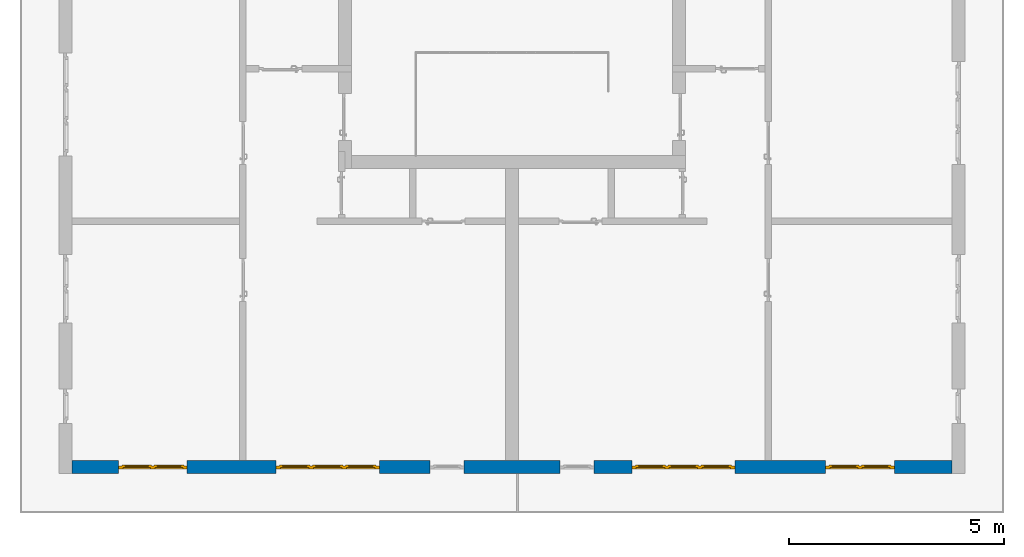
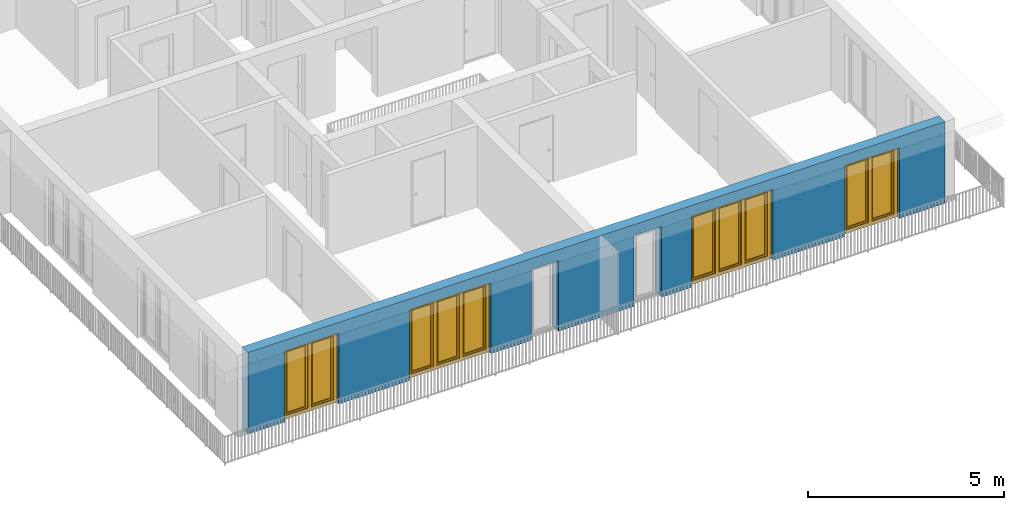
# One storey, part 9 of 54: 4 windows, 1 wall, 6 openings.
"""IFC4 building model written with IfcOpenShell, lengths in metres."""

from ifc_helpers import new_model, entity, si_unit, converted_unit, derived_unit, direction, frame, origin_with_axes, place, context, subcontext, project, spatial, polygons, source, transform, mapped, material, type_object, element, fill, save


model = new_model("IFC4")

# Units and contexts
model_context = context("Model", 3, precision=1e-05, world=origin_with_axes(), true_north=direction((0.0, 1.0)))
body_context = subcontext(model_context, "Body", "Model", "MODEL_VIEW")
ifc_project = project(units=[si_unit("LENGTHUNIT", "METRE"), si_unit("AREAUNIT", "SQUARE_METRE"), si_unit("VOLUMEUNIT", "CUBIC_METRE"), converted_unit("PLANEANGLEUNIT", "DEGREE", entity("IfcPlaneAngleMeasure", 0.0174532925199), si_unit("PLANEANGLEUNIT", "RADIAN"), dimensions=[0, 0, 0, 0, 0, 0, 0]), converted_unit("TIMEUNIT", "Year", entity("IfcTimeMeasure", 31556926.0), si_unit("TIMEUNIT", "SECOND"), dimensions=[0, 0, 1, 0, 0, 0, 0]), si_unit("MASSUNIT", "GRAM", prefix="KILO"), si_unit("THERMODYNAMICTEMPERATUREUNIT", "DEGREE_CELSIUS"), si_unit("LUMINOUSINTENSITYUNIT", "LUMEN"), si_unit("ENERGYUNIT", "JOULE", prefix="MEGA"), derived_unit("THERMALCONDUCTANCEUNIT", [(si_unit("POWERUNIT", "WATT"), 1), (si_unit("LENGTHUNIT", "METRE"), -1), (si_unit("THERMODYNAMICTEMPERATUREUNIT", "KELVIN"), -1)]), derived_unit("SPECIFICHEATCAPACITYUNIT", [(si_unit("ENERGYUNIT", "JOULE"), 1), (si_unit("MASSUNIT", "GRAM", prefix="KILO"), -1), (si_unit("THERMODYNAMICTEMPERATUREUNIT", "KELVIN"), -1)]), derived_unit("MASSDENSITYUNIT", [(si_unit("MASSUNIT", "GRAM", prefix="KILO"), 1), (si_unit("VOLUMEUNIT", "CUBIC_METRE"), -1)])], contexts=[model_context])

# Site, building, storey
site_placement = place(None, origin_with_axes())
site = spatial("IfcSite", under=ifc_project, at=site_placement, CompositionType="ELEMENT")
building_placement = place(site_placement, origin_with_axes())
building = spatial("IfcBuilding", under=site, at=building_placement, CompositionType="ELEMENT")
storey_placement = place(building_placement, frame((0.0, 0.0, 9.18), z_axis=(0.0, 0.0, 1.0), x_axis=(1.0, 0.0, 0.0)))
storey = spatial("IfcBuildingStorey", under=building, at=storey_placement, Name="3. Geschoss", CompositionType="ELEMENT", Elevation=9.18)

# Wall, openings, windows
ifc_material = material()
wall_type = type_object("IfcWallType", Name="300", PredefinedType="NOTDEFINED")
wall_placement = place(storey_placement, frame((9.3378006196, -9.92881223104, 0.0), z_axis=(0.0, 0.0, 1.0), x_axis=(-1.0, 0.0, 0.0)))
wall = element("IfcWall", 1, at=wall_placement, inside=storey, type_object=wall_type, material=ifc_material, Name="Wand-001", PredefinedType="NOTDEFINED", context=body_context, shape_type="Tessellation", body=[
    polygons([(12.4515538751, -0.3, 2.2), (12.4515538751, -0.3, 0.0), (13.63, -0.3, 0.0), (13.63, -0.3, 2.2), (16.03, -0.3, 2.2), (16.03, -0.3, 0.0), (18.0998837323, -0.3, 0.0), (18.0998837323, -0.3, 2.2), (19.6998837323, -0.3, 2.2), (19.6998837323, -0.3, 0.0), (20.78, -0.3, 0.0), (20.78, -0.3, 2.54), (0.3, -0.3, 2.54), (0.3, -0.3, 0.0), (1.6378225413, -0.3, 0.0), (1.6378225413, -0.3, 2.2), (3.2378225413, -0.3, 2.2), (3.2378225413, -0.3, 0.0), (5.35, -0.3, 0.0), (5.35, -0.3, 2.2), (7.75, -0.3, 2.2), (7.75, -0.3, 0.0), (8.62617854928, -0.3, 0.0), (8.62617854928, -0.3, 2.2), (9.42617854928, -0.3, 2.2), (9.42617854928, -0.3, 0.0), (11.6515538751, -0.3, 0.0), (11.6515538751, -0.3, 2.2), (12.4515538751, -0.1, 0.0), (12.4515538751, 0.0, 2.2), (12.4515538751, 0.0, 0.0), (13.63, 0.0, 0.0), (13.63, 0.0, 2.2), (16.03, 0.0, 2.2), (16.03, 0.0, 0.0), (18.0998837323, 0.0, 0.0), (18.0998837323, 0.0, 2.2), (19.6998837323, 0.0, 2.2), (19.6998837323, 0.0, 0.0), (20.78, 0.0, 0.0), (20.78, 0.0, 2.54), (0.3, 0.0, 2.54), (0.3, 0.0, 0.0), (1.6378225413, 0.0, 0.0), (1.6378225413, 0.0, 2.2), (3.2378225413, 0.0, 2.2), (3.2378225413, 0.0, 0.0), (5.35, 0.0, 0.0), (5.35, 0.0, 2.2), (7.75, 0.0, 2.2), (7.75, 0.0, 0.0), (8.62617854928, 0.0, 0.0), (8.62617854928, 0.0, 2.2), (9.42617854928, 0.0, 2.2), (9.42617854928, 0.0, 0.0), (11.6515538751, -0.1, 0.0), (11.6515538751, 0.0, 0.0), (11.6515538751, 0.0, 2.2)], [[[1, 2, 3, 4, 5, 6, 7, 8, 9, 10, 11, 12, 13, 14, 15, 16, 17, 18, 19, 20, 21, 22, 23, 24, 25, 26, 27, 28]], [[29, 2, 1, 30, 31]], [[2, 29, 31, 32, 3]], [[32, 33, 4, 3]], [[33, 34, 5, 4]], [[34, 35, 6, 5]], [[36, 7, 6, 35]], [[36, 37, 8, 7]], [[37, 38, 9, 8]], [[38, 39, 10, 9]], [[40, 11, 10, 39]], [[40, 41, 12, 11]], [[41, 42, 13, 12]], [[14, 13, 42, 43]], [[15, 14, 43, 44]], [[16, 15, 44, 45]], [[17, 16, 45, 46]], [[18, 17, 46, 47]], [[19, 18, 47, 48]], [[20, 19, 48, 49]], [[21, 20, 49, 50]], [[22, 21, 50, 51]], [[51, 52, 23, 22]], [[52, 53, 24, 23]], [[53, 54, 25, 24]], [[54, 55, 26, 25]], [[56, 27, 26, 55, 57]], [[28, 27, 56, 57, 58]], [[1, 28, 58, 30]], [[32, 31, 30, 58, 57, 55, 54, 53, 52, 51, 50, 49, 48, 47, 46, 45, 44, 43, 42, 41, 40, 39, 38, 37, 36, 35, 34, 33]]], closed=True),
])
opening_1_placement = place(wall_placement, frame((18.8998837323, 0.0, 0.0), z_axis=(0.0, 0.0, 1.0), x_axis=(1.0, 0.0, 0.0)))
opening_1 = element("IfcOpeningElement", 2, at=opening_1_placement, cuts=wall, Name="Fenster-001", context=body_context, identifier="Reference", shape_type="Tessellation", body=[
    polygons([(-0.8, -0.1, 0.0), (-0.8, -0.1, 2.2), (-0.8, 0.001, 2.2), (-0.8, 0.001, 0.0), (-0.8, -0.301, 0.0), (-0.8, -0.301, 2.2), (0.8, -0.1, 2.2), (0.8, 0.001, 2.2), (0.8, -0.301, 2.2), (0.8, 0.001, 0.0), (0.8, -0.1, 0.0), (0.8, -0.301, 0.0)], [[[1, 2, 3, 4]], [[2, 1, 5, 6]], [[7, 8, 3, 2, 6, 9]], [[8, 10, 4, 3]], [[1, 4, 10, 11, 12, 5]], [[6, 5, 12, 9]], [[7, 11, 10, 8]], [[11, 7, 9, 12]]], closed=True),
])
opening_2_placement = place(wall_placement, frame((2.4378225413, 0.0, 0.0), z_axis=(0.0, 0.0, 1.0), x_axis=(1.0, 0.0, 0.0)))
opening_2 = element("IfcOpeningElement", 3, at=opening_2_placement, cuts=wall, Name="Fenster-002", context=body_context, identifier="Reference", shape_type="Tessellation", body=[
    polygons([(-0.8, -0.1, 0.0), (-0.8, -0.1, 2.2), (-0.8, 0.000999999999999, 2.2), (-0.8, 0.000999999999999, 0.0), (-0.8, -0.301, 0.0), (-0.8, -0.301, 2.2), (0.8, -0.1, 2.2), (0.8, 0.000999999999999, 2.2), (0.8, -0.301, 2.2), (0.8, 0.000999999999999, 0.0), (0.8, -0.1, 0.0), (0.8, -0.301, 0.0)], [[[1, 2, 3, 4]], [[2, 1, 5, 6]], [[7, 8, 3, 2, 6, 9]], [[8, 10, 4, 3]], [[1, 4, 10, 11, 12, 5]], [[6, 5, 12, 9]], [[7, 11, 10, 8]], [[11, 7, 9, 12]]], closed=True),
])
opening_3_placement = place(wall_placement, frame((14.83, 0.0, 0.0), z_axis=(0.0, 0.0, 1.0), x_axis=(1.0, 0.0, 0.0)))
opening_3 = element("IfcOpeningElement", 4, at=opening_3_placement, cuts=wall, Name="Fenster-002", context=body_context, identifier="Reference", shape_type="Tessellation", body=[
    polygons([(-1.2, -0.1, 0.0), (-1.2, -0.1, 2.2), (-1.2, 0.001, 2.2), (-1.2, 0.001, 0.0), (-1.2, -0.301, 0.0), (-1.2, -0.301, 2.2), (1.2, -0.1, 2.2), (1.2, 0.001, 2.2), (1.2, -0.301, 2.2), (1.2, 0.001, 0.0), (1.2, -0.1, 0.0), (1.2, -0.301, 0.0)], [[[1, 2, 3, 4]], [[2, 1, 5, 6]], [[7, 8, 3, 2, 6, 9]], [[8, 10, 4, 3]], [[1, 4, 10, 11, 12, 5]], [[6, 5, 12, 9]], [[7, 11, 10, 8]], [[11, 7, 9, 12]]], closed=True),
])
opening_4_placement = place(wall_placement, frame((6.55, 0.0, 0.0), z_axis=(0.0, 0.0, 1.0), x_axis=(1.0, 0.0, 0.0)))
opening_4 = element("IfcOpeningElement", 5, at=opening_4_placement, cuts=wall, Name="Fenster-003", context=body_context, identifier="Reference", shape_type="Tessellation", body=[
    polygons([(-1.2, -0.1, 0.0), (-1.2, -0.1, 2.2), (-1.2, 0.000999999999999, 2.2), (-1.2, 0.000999999999999, 0.0), (-1.2, -0.301, 0.0), (-1.2, -0.301, 2.2), (1.2, -0.1, 2.2), (1.2, 0.001, 2.2), (1.2, -0.301, 2.2), (1.2, 0.001, 0.0), (1.2, -0.1, 0.0), (1.2, -0.301, 0.0)], [[[1, 2, 3, 4]], [[2, 1, 5, 6]], [[7, 8, 3, 2, 6, 9]], [[8, 10, 4, 3]], [[1, 4, 10, 11, 12, 5]], [[6, 5, 12, 9]], [[7, 11, 10, 8]], [[11, 7, 9, 12]]], closed=True),
])
opening_5_placement = place(wall_placement, frame((9.02617854928, 0.0, 0.0), z_axis=(0.0, 0.0, 1.0), x_axis=(1.0, 0.0, 0.0)))
element("IfcOpeningElement", 6, at=opening_5_placement, cuts=wall, Name="Fenster-003", context=body_context, identifier="Reference", shape_type="Tessellation", body=[
    polygons([(-0.4, -0.1, 0.0), (-0.4, -0.1, 2.2), (-0.4, 0.001, 2.2), (-0.4, 0.001, 0.0), (-0.4, -0.301, 0.0), (-0.4, -0.301, 2.2), (0.4, -0.1, 2.2), (0.4, 0.001, 2.2), (0.4, -0.301, 2.2), (0.4, 0.001, 0.0), (0.4, -0.1, 0.0), (0.4, -0.301, 0.0)], [[[1, 2, 3, 4]], [[2, 1, 5, 6]], [[7, 8, 3, 2, 6, 9]], [[8, 10, 4, 3]], [[1, 4, 10, 11, 12, 5]], [[6, 5, 12, 9]], [[7, 11, 10, 8]], [[11, 7, 9, 12]]], closed=True),
])
opening_6_placement = place(wall_placement, frame((12.0515538751, 0.0, 0.0), z_axis=(0.0, 0.0, 1.0), x_axis=(1.0, 0.0, 0.0)))
element("IfcOpeningElement", 7, at=opening_6_placement, cuts=wall, Name="Fenster-003", context=body_context, identifier="Reference", shape_type="Tessellation", body=[
    polygons([(-0.4, -0.1, 0.0), (-0.4, -0.1, 2.2), (-0.4, 0.001, 2.2), (-0.4, 0.001, 0.0), (-0.4, -0.301, 0.0), (-0.4, -0.301, 2.2), (0.4, -0.1, 2.2), (0.4, 0.001, 2.2), (0.4, -0.301, 2.2), (0.4, 0.001, 0.0), (0.4, -0.1, 0.0), (0.4, -0.301, 0.0)], [[[1, 2, 3, 4]], [[2, 1, 5, 6]], [[7, 8, 3, 2, 6, 9]], [[8, 10, 4, 3]], [[1, 4, 10, 11, 12, 5]], [[6, 5, 12, 9]], [[7, 11, 10, 8]], [[11, 7, 9, 12]]], closed=True),
])
window_type_1 = type_object("IfcWindowType", Name="2-1+1 26", PartitioningType="DOUBLE_PANEL_VERTICAL", PredefinedType="WINDOW")
shared_shape_1 = source(origin_with_axes(), body_context, "Body", "Tessellation", [
    polygons([(-0.8, -0.07, 0.0), (-0.8, 0.0, 0.0), (-0.7, 0.0, 0.1), (-0.7, -0.07, 0.1), (-0.8, -0.07, 2.2), (-0.8, 0.0, 2.2), (-0.7, 0.0, 2.1), (-0.7, -0.07, 2.1)], [[[1, 2, 3, 4]], [[5, 6, 2, 1]], [[2, 6, 7, 3]], [[4, 3, 7, 8]], [[1, 4, 8, 5]], [[8, 7, 6, 5]]], closed=True),
    polygons([(0.8, -0.07, 0.0), (0.8, 0.0, 0.0), (0.8, 0.0, 2.2), (0.8, -0.07, 2.2), (0.7, -0.07, 0.1), (0.7, 0.0, 0.1), (0.7, 0.0, 2.1), (0.7, -0.07, 2.1)], [[[1, 2, 3, 4]], [[5, 6, 2, 1]], [[2, 6, 7, 3]], [[4, 3, 7, 8]], [[1, 4, 8, 5]], [[8, 7, 6, 5]]], closed=True),
    polygons([(-0.8, -0.07, 0.0), (-0.8, 0.0, 0.0), (0.8, 0.0, 0.0), (0.8, -0.07, 0.0), (-0.7, -0.07, 0.1), (-0.7, 0.0, 0.1), (-0.05, 0.0, 0.1), (0.05, 0.0, 0.1), (0.7, 0.0, 0.1), (0.7, -0.07, 0.1), (0.05, -0.07, 0.1), (-0.05, -0.07, 0.1)], [[[1, 2, 3, 4]], [[5, 6, 2, 1]], [[2, 6, 7, 8, 9, 3]], [[4, 3, 9, 10]], [[1, 4, 10, 11, 12, 5]], [[12, 7, 6, 5]], [[11, 8, 7, 12]], [[10, 9, 8, 11]]], closed=True),
    polygons([(-0.8, -0.07, 2.2), (-0.8, 0.0, 2.2), (-0.7, 0.0, 2.1), (-0.7, -0.07, 2.1), (0.8, -0.07, 2.2), (0.8, 0.0, 2.2), (0.7, 0.0, 2.1), (0.05, 0.0, 2.1), (-0.05, 0.0, 2.1), (-0.05, -0.07, 2.1), (0.05, -0.07, 2.1), (0.7, -0.07, 2.1)], [[[1, 2, 3, 4]], [[5, 6, 2, 1]], [[2, 6, 7, 8, 9, 3]], [[4, 3, 9, 10]], [[1, 4, 10, 11, 12, 5]], [[12, 7, 6, 5]], [[11, 8, 7, 12]], [[10, 9, 8, 11]]], closed=True),
    polygons([(-0.05, -0.07, 0.1), (-0.05, 0.0, 0.1), (0.05, 0.0, 0.1), (0.05, -0.07, 0.1), (-0.05, -0.07, 2.1), (-0.05, 0.0, 2.1), (0.05, 0.0, 2.1), (0.05, -0.07, 2.1)], [[[1, 2, 3, 4]], [[5, 6, 2, 1]], [[2, 6, 7, 3]], [[4, 3, 7, 8]], [[1, 4, 8, 5]], [[8, 7, 6, 5]]], closed=True),
    polygons([(-0.72, 0.0, 0.08), (-0.72, 0.03, 0.08), (-0.65, 0.03, 0.15), (-0.65, 0.0, 0.15), (-0.72, 0.0, 2.12), (-0.72, 0.03, 2.12), (-0.65, 0.03, 2.05), (-0.65, 0.0, 2.05)], [[[1, 2, 3, 4]], [[5, 6, 2, 1]], [[2, 6, 7, 3]], [[4, 3, 7, 8]], [[1, 4, 8, 5]], [[8, 7, 6, 5]]], closed=True),
    polygons([(-0.03, 0.0, 0.08), (-0.1, 0.0, 0.15), (-0.1, 0.03, 0.15), (-0.03, 0.03, 0.08), (-0.03, 0.0, 2.12), (-0.1, 0.0, 2.05), (-0.1, 0.03, 2.05), (-0.03, 0.03, 2.12)], [[[1, 2, 3, 4]], [[1, 5, 6, 2]], [[2, 6, 7, 3]], [[4, 3, 7, 8]], [[5, 1, 4, 8]], [[6, 5, 8, 7]]], closed=True),
    polygons([(-0.72, 0.0, 0.08), (-0.72, 0.03, 0.08), (-0.03, 0.03, 0.08), (-0.03, 0.0, 0.08), (-0.65, 0.0, 0.15), (-0.65, 0.03, 0.15), (-0.1, 0.03, 0.15), (-0.1, 0.0, 0.15)], [[[1, 2, 3, 4]], [[5, 6, 2, 1]], [[2, 6, 7, 3]], [[4, 3, 7, 8]], [[1, 4, 8, 5]], [[8, 7, 6, 5]]], closed=True),
    polygons([(-0.72, 0.0, 2.12), (-0.03, 0.0, 2.12), (-0.03, 0.03, 2.12), (-0.72, 0.03, 2.12), (-0.65, 0.0, 2.05), (-0.1, 0.0, 2.05), (-0.1, 0.03, 2.05), (-0.65, 0.03, 2.05)], [[[1, 2, 3, 4]], [[1, 5, 6, 2]], [[2, 6, 7, 3]], [[4, 3, 7, 8]], [[5, 1, 4, 8]], [[6, 5, 8, 7]]], closed=True),
    polygons([(-0.7, -0.03, 0.1), (-0.7, 0.0, 0.1), (-0.65, 0.0, 0.15), (-0.65, -0.03, 0.15), (-0.7, -0.03, 2.1), (-0.7, 0.0, 2.1), (-0.65, 0.0, 2.05), (-0.65, -0.03, 2.05)], [[[1, 2, 3, 4]], [[5, 6, 2, 1]], [[2, 6, 7, 3]], [[4, 3, 7, 8]], [[1, 4, 8, 5]], [[8, 7, 6, 5]]], closed=True),
    polygons([(-0.05, -0.03, 0.1), (-0.1, -0.03, 0.15), (-0.1, 0.0, 0.15), (-0.05, 0.0, 0.1), (-0.05, -0.03, 2.1), (-0.1, -0.03, 2.05), (-0.1, 0.0, 2.05), (-0.05, 0.0, 2.1)], [[[1, 2, 3, 4]], [[1, 5, 6, 2]], [[2, 6, 7, 3]], [[4, 3, 7, 8]], [[5, 1, 4, 8]], [[6, 5, 8, 7]]], closed=True),
    polygons([(-0.7, -0.03, 0.1), (-0.7, 0.0, 0.1), (-0.05, 0.0, 0.1), (-0.05, -0.03, 0.1), (-0.65, -0.03, 0.15), (-0.65, 0.0, 0.15), (-0.1, 0.0, 0.15), (-0.1, -0.03, 0.15)], [[[1, 2, 3, 4]], [[5, 6, 2, 1]], [[2, 6, 7, 3]], [[4, 3, 7, 8]], [[1, 4, 8, 5]], [[8, 7, 6, 5]]], closed=True),
    polygons([(-0.7, -0.03, 2.1), (-0.05, -0.03, 2.1), (-0.05, 0.0, 2.1), (-0.7, 0.0, 2.1), (-0.65, -0.03, 2.05), (-0.1, -0.03, 2.05), (-0.1, 0.0, 2.05), (-0.65, 0.0, 2.05)], [[[1, 2, 3, 4]], [[1, 5, 6, 2]], [[2, 6, 7, 3]], [[4, 3, 7, 8]], [[5, 1, 4, 8]], [[6, 5, 8, 7]]], closed=True),
    polygons([(-0.65, -0.005, 0.15), (-0.65, 0.005, 0.15), (-0.1, 0.005, 0.15), (-0.1, -0.005, 0.15), (-0.65, -0.005, 2.05), (-0.65, 0.005, 2.05), (-0.1, 0.005, 2.05), (-0.1, -0.005, 2.05)], [[[1, 2, 3, 4]], [[5, 6, 2, 1]], [[2, 6, 7, 3]], [[4, 3, 7, 8]], [[1, 4, 8, 5]], [[8, 7, 6, 5]]], closed=True),
    polygons([(0.03, 0.0, 0.08), (0.03, 0.03, 0.08), (0.1, 0.03, 0.15), (0.1, 0.0, 0.15), (0.03, 0.0, 2.12), (0.03, 0.03, 2.12), (0.1, 0.03, 2.05), (0.1, 0.0, 2.05)], [[[1, 2, 3, 4]], [[5, 6, 2, 1]], [[2, 6, 7, 3]], [[4, 3, 7, 8]], [[1, 4, 8, 5]], [[8, 7, 6, 5]]], closed=True),
    polygons([(0.72, 0.0, 0.08), (0.65, 0.0, 0.15), (0.65, 0.03, 0.15), (0.72, 0.03, 0.08), (0.72, 0.0, 2.12), (0.65, 0.0, 2.05), (0.65, 0.03, 2.05), (0.72, 0.03, 2.12)], [[[1, 2, 3, 4]], [[1, 5, 6, 2]], [[2, 6, 7, 3]], [[4, 3, 7, 8]], [[5, 1, 4, 8]], [[6, 5, 8, 7]]], closed=True),
    polygons([(0.03, 0.0, 0.08), (0.03, 0.03, 0.08), (0.72, 0.03, 0.08), (0.72, 0.0, 0.08), (0.1, 0.0, 0.15), (0.1, 0.03, 0.15), (0.65, 0.03, 0.15), (0.65, 0.0, 0.15)], [[[1, 2, 3, 4]], [[5, 6, 2, 1]], [[2, 6, 7, 3]], [[4, 3, 7, 8]], [[1, 4, 8, 5]], [[8, 7, 6, 5]]], closed=True),
    polygons([(0.03, 0.0, 2.12), (0.72, 0.0, 2.12), (0.72, 0.03, 2.12), (0.03, 0.03, 2.12), (0.1, 0.0, 2.05), (0.65, 0.0, 2.05), (0.65, 0.03, 2.05), (0.1, 0.03, 2.05)], [[[1, 2, 3, 4]], [[1, 5, 6, 2]], [[2, 6, 7, 3]], [[4, 3, 7, 8]], [[5, 1, 4, 8]], [[6, 5, 8, 7]]], closed=True),
    polygons([(0.05, -0.03, 0.1), (0.05, 0.0, 0.1), (0.1, 0.0, 0.15), (0.1, -0.03, 0.15), (0.05, -0.03, 2.1), (0.05, 0.0, 2.1), (0.1, 0.0, 2.05), (0.1, -0.03, 2.05)], [[[1, 2, 3, 4]], [[5, 6, 2, 1]], [[2, 6, 7, 3]], [[4, 3, 7, 8]], [[1, 4, 8, 5]], [[8, 7, 6, 5]]], closed=True),
    polygons([(0.7, -0.03, 0.1), (0.65, -0.03, 0.15), (0.65, 0.0, 0.15), (0.7, 0.0, 0.1), (0.7, -0.03, 2.1), (0.65, -0.03, 2.05), (0.65, 0.0, 2.05), (0.7, 0.0, 2.1)], [[[1, 2, 3, 4]], [[1, 5, 6, 2]], [[2, 6, 7, 3]], [[4, 3, 7, 8]], [[5, 1, 4, 8]], [[6, 5, 8, 7]]], closed=True),
    polygons([(0.05, -0.03, 0.1), (0.05, 0.0, 0.1), (0.7, 0.0, 0.1), (0.7, -0.03, 0.1), (0.1, -0.03, 0.15), (0.1, 0.0, 0.15), (0.65, 0.0, 0.15), (0.65, -0.03, 0.15)], [[[1, 2, 3, 4]], [[5, 6, 2, 1]], [[2, 6, 7, 3]], [[4, 3, 7, 8]], [[1, 4, 8, 5]], [[8, 7, 6, 5]]], closed=True),
    polygons([(0.05, -0.03, 2.1), (0.7, -0.03, 2.1), (0.7, 0.0, 2.1), (0.05, 0.0, 2.1), (0.1, -0.03, 2.05), (0.65, -0.03, 2.05), (0.65, 0.0, 2.05), (0.1, 0.0, 2.05)], [[[1, 2, 3, 4]], [[1, 5, 6, 2]], [[2, 6, 7, 3]], [[4, 3, 7, 8]], [[5, 1, 4, 8]], [[6, 5, 8, 7]]], closed=True),
    polygons([(0.1, -0.005, 0.15), (0.1, 0.005, 0.15), (0.65, 0.005, 0.15), (0.65, -0.005, 0.15), (0.1, -0.005, 2.05), (0.1, 0.005, 2.05), (0.65, 0.005, 2.05), (0.65, -0.005, 2.05)], [[[1, 2, 3, 4]], [[5, 6, 2, 1]], [[2, 6, 7, 3]], [[4, 3, 7, 8]], [[1, 4, 8, 5]], [[8, 7, 6, 5]]], closed=True),
])
window_1_placement = place(opening_1_placement, frame((0.8, 0.0, 0.0), z_axis=(0.0, 0.0, 1.0), x_axis=(-1.0, 0.0, 0.0)))
window_1 = element("IfcWindow", 8, at=window_1_placement, inside=storey, type_object=window_type_1, Name="Fenster-001", OverallHeight=2.2, OverallWidth=1.6, PredefinedType="WINDOW", context=body_context, shape_type="MappedRepresentation", body=[
    mapped(shared_shape_1, transform((0.8, 0.17, 0.0))),
])
fill(opening_1, window_1)
window_2_placement = place(opening_2_placement, frame((0.8, 0.0, 0.0), z_axis=(0.0, 0.0, 1.0), x_axis=(-1.0, 0.0, 0.0)))
window_2 = element("IfcWindow", 9, at=window_2_placement, inside=storey, type_object=window_type_1, Name="Fenster-002", OverallHeight=2.2, OverallWidth=1.6, PredefinedType="WINDOW", context=body_context, shape_type="MappedRepresentation", body=[
    mapped(shared_shape_1, transform((0.8, 0.17, 0.0))),
])
fill(opening_2, window_2)
window_type_2 = type_object("IfcWindowType", Name="3-1+1+1 26", PartitioningType="TRIPLE_PANEL_VERTICAL", PredefinedType="WINDOW")
shared_shape_2 = source(origin_with_axes(), body_context, "Body", "Tessellation", [
    polygons([(-1.2, -0.07, 0.0), (-1.2, 0.0, 0.0), (-1.1, 0.0, 0.1), (-1.1, -0.07, 0.1), (-1.2, -0.07, 2.2), (-1.2, 0.0, 2.2), (-1.1, 0.0, 2.1), (-1.1, -0.07, 2.1)], [[[1, 2, 3, 4]], [[5, 6, 2, 1]], [[2, 6, 7, 3]], [[4, 3, 7, 8]], [[1, 4, 8, 5]], [[8, 7, 6, 5]]], closed=True),
    polygons([(1.2, -0.07, 0.0), (1.2, 0.0, 0.0), (1.2, 0.0, 2.2), (1.2, -0.07, 2.2), (1.1, -0.07, 0.1), (1.1, 0.0, 0.1), (1.1, 0.0, 2.1), (1.1, -0.07, 2.1)], [[[1, 2, 3, 4]], [[5, 6, 2, 1]], [[2, 6, 7, 3]], [[4, 3, 7, 8]], [[1, 4, 8, 5]], [[8, 7, 6, 5]]], closed=True),
    polygons([(-1.2, -0.07, 0.0), (-1.2, 0.0, 0.0), (1.2, 0.0, 0.0), (1.2, -0.07, 0.0), (-1.1, -0.07, 0.1), (-1.1, 0.0, 0.1), (-0.433333333333, 0.0, 0.1), (-0.333333333333, 0.0, 0.1), (0.333333333333, 0.0, 0.1), (0.433333333333, 0.0, 0.1), (1.1, 0.0, 0.1), (1.1, -0.07, 0.1), (0.433333333333, -0.07, 0.1), (0.333333333333, -0.07, 0.1), (-0.333333333333, -0.07, 0.1), (-0.433333333333, -0.07, 0.1)], [[[1, 2, 3, 4]], [[5, 6, 2, 1]], [[2, 6, 7, 8, 9, 10, 11, 3]], [[4, 3, 11, 12]], [[1, 4, 12, 13, 14, 15, 16, 5]], [[16, 7, 6, 5]], [[15, 8, 7, 16]], [[14, 9, 8, 15]], [[13, 10, 9, 14]], [[12, 11, 10, 13]]], closed=True),
    polygons([(-1.2, -0.07, 2.2), (-1.2, 0.0, 2.2), (-1.1, 0.0, 2.1), (-1.1, -0.07, 2.1), (1.2, -0.07, 2.2), (1.2, 0.0, 2.2), (1.1, 0.0, 2.1), (0.433333333333, 0.0, 2.1), (0.333333333333, 0.0, 2.1), (-0.333333333333, 0.0, 2.1), (-0.433333333333, 0.0, 2.1), (-0.433333333333, -0.07, 2.1), (-0.333333333333, -0.07, 2.1), (0.333333333333, -0.07, 2.1), (0.433333333333, -0.07, 2.1), (1.1, -0.07, 2.1)], [[[1, 2, 3, 4]], [[5, 6, 2, 1]], [[2, 6, 7, 8, 9, 10, 11, 3]], [[4, 3, 11, 12]], [[1, 4, 12, 13, 14, 15, 16, 5]], [[16, 7, 6, 5]], [[15, 8, 7, 16]], [[14, 9, 8, 15]], [[13, 10, 9, 14]], [[12, 11, 10, 13]]], closed=True),
    polygons([(0.333333333333, -0.07, 0.1), (0.333333333333, 0.0, 0.1), (0.433333333333, 0.0, 0.1), (0.433333333333, -0.07, 0.1), (0.333333333333, -0.07, 2.1), (0.333333333333, 0.0, 2.1), (0.433333333333, 0.0, 2.1), (0.433333333333, -0.07, 2.1)], [[[1, 2, 3, 4]], [[5, 6, 2, 1]], [[2, 6, 7, 3]], [[4, 3, 7, 8]], [[1, 4, 8, 5]], [[8, 7, 6, 5]]], closed=True),
    polygons([(-0.433333333333, -0.07, 0.1), (-0.433333333333, 0.0, 0.1), (-0.333333333333, 0.0, 0.1), (-0.333333333333, -0.07, 0.1), (-0.433333333333, -0.07, 2.1), (-0.433333333333, 0.0, 2.1), (-0.333333333333, 0.0, 2.1), (-0.333333333333, -0.07, 2.1)], [[[1, 2, 3, 4]], [[5, 6, 2, 1]], [[2, 6, 7, 3]], [[4, 3, 7, 8]], [[1, 4, 8, 5]], [[8, 7, 6, 5]]], closed=True),
    polygons([(-1.12, 0.0, 0.08), (-1.12, 0.03, 0.08), (-1.05, 0.03, 0.15), (-1.05, 0.0, 0.15), (-1.12, 0.0, 2.12), (-1.12, 0.03, 2.12), (-1.05, 0.03, 2.05), (-1.05, 0.0, 2.05)], [[[1, 2, 3, 4]], [[5, 6, 2, 1]], [[2, 6, 7, 3]], [[4, 3, 7, 8]], [[1, 4, 8, 5]], [[8, 7, 6, 5]]], closed=True),
    polygons([(-0.413333333333, 0.0, 0.08), (-0.483333333333, 0.0, 0.15), (-0.483333333333, 0.03, 0.15), (-0.413333333333, 0.03, 0.08), (-0.413333333333, 0.0, 2.12), (-0.483333333333, 0.0, 2.05), (-0.483333333333, 0.03, 2.05), (-0.413333333333, 0.03, 2.12)], [[[1, 2, 3, 4]], [[1, 5, 6, 2]], [[2, 6, 7, 3]], [[4, 3, 7, 8]], [[5, 1, 4, 8]], [[6, 5, 8, 7]]], closed=True),
    polygons([(-1.12, 0.0, 0.08), (-1.12, 0.03, 0.08), (-0.413333333333, 0.03, 0.08), (-0.413333333333, 0.0, 0.08), (-1.05, 0.0, 0.15), (-1.05, 0.03, 0.15), (-0.483333333333, 0.03, 0.15), (-0.483333333333, 0.0, 0.15)], [[[1, 2, 3, 4]], [[5, 6, 2, 1]], [[2, 6, 7, 3]], [[4, 3, 7, 8]], [[1, 4, 8, 5]], [[8, 7, 6, 5]]], closed=True),
    polygons([(-1.12, 0.0, 2.12), (-0.413333333333, 0.0, 2.12), (-0.413333333333, 0.03, 2.12), (-1.12, 0.03, 2.12), (-1.05, 0.0, 2.05), (-0.483333333333, 0.0, 2.05), (-0.483333333333, 0.03, 2.05), (-1.05, 0.03, 2.05)], [[[1, 2, 3, 4]], [[1, 5, 6, 2]], [[2, 6, 7, 3]], [[4, 3, 7, 8]], [[5, 1, 4, 8]], [[6, 5, 8, 7]]], closed=True),
    polygons([(-1.1, -0.03, 0.1), (-1.1, 0.0, 0.1), (-1.05, 0.0, 0.15), (-1.05, -0.03, 0.15), (-1.1, -0.03, 2.1), (-1.1, 0.0, 2.1), (-1.05, 0.0, 2.05), (-1.05, -0.03, 2.05)], [[[1, 2, 3, 4]], [[5, 6, 2, 1]], [[2, 6, 7, 3]], [[4, 3, 7, 8]], [[1, 4, 8, 5]], [[8, 7, 6, 5]]], closed=True),
    polygons([(-0.433333333333, -0.03, 0.1), (-0.483333333333, -0.03, 0.15), (-0.483333333333, 0.0, 0.15), (-0.433333333333, 0.0, 0.1), (-0.433333333333, -0.03, 2.1), (-0.483333333333, -0.03, 2.05), (-0.483333333333, 0.0, 2.05), (-0.433333333333, 0.0, 2.1)], [[[1, 2, 3, 4]], [[1, 5, 6, 2]], [[2, 6, 7, 3]], [[4, 3, 7, 8]], [[5, 1, 4, 8]], [[6, 5, 8, 7]]], closed=True),
    polygons([(-1.1, -0.03, 0.1), (-1.1, 0.0, 0.1), (-0.433333333333, 0.0, 0.1), (-0.433333333333, -0.03, 0.1), (-1.05, -0.03, 0.15), (-1.05, 0.0, 0.15), (-0.483333333333, 0.0, 0.15), (-0.483333333333, -0.03, 0.15)], [[[1, 2, 3, 4]], [[5, 6, 2, 1]], [[2, 6, 7, 3]], [[4, 3, 7, 8]], [[1, 4, 8, 5]], [[8, 7, 6, 5]]], closed=True),
    polygons([(-1.1, -0.03, 2.1), (-0.433333333333, -0.03, 2.1), (-0.433333333333, 0.0, 2.1), (-1.1, 0.0, 2.1), (-1.05, -0.03, 2.05), (-0.483333333333, -0.03, 2.05), (-0.483333333333, 0.0, 2.05), (-1.05, 0.0, 2.05)], [[[1, 2, 3, 4]], [[1, 5, 6, 2]], [[2, 6, 7, 3]], [[4, 3, 7, 8]], [[5, 1, 4, 8]], [[6, 5, 8, 7]]], closed=True),
    polygons([(-1.05, -0.005, 0.15), (-1.05, 0.005, 0.15), (-0.483333333333, 0.005, 0.15), (-0.483333333333, -0.005, 0.15), (-1.05, -0.005, 2.05), (-1.05, 0.005, 2.05), (-0.483333333333, 0.005, 2.05), (-0.483333333333, -0.005, 2.05)], [[[1, 2, 3, 4]], [[5, 6, 2, 1]], [[2, 6, 7, 3]], [[4, 3, 7, 8]], [[1, 4, 8, 5]], [[8, 7, 6, 5]]], closed=True),
    polygons([(-0.353333333333, 0.0, 0.08), (-0.353333333333, 0.03, 0.08), (-0.283333333333, 0.03, 0.15), (-0.283333333333, 0.0, 0.15), (-0.353333333333, 0.0, 2.12), (-0.353333333333, 0.03, 2.12), (-0.283333333333, 0.03, 2.05), (-0.283333333333, 0.0, 2.05)], [[[1, 2, 3, 4]], [[5, 6, 2, 1]], [[2, 6, 7, 3]], [[4, 3, 7, 8]], [[1, 4, 8, 5]], [[8, 7, 6, 5]]], closed=True),
    polygons([(0.353333333333, 0.0, 0.08), (0.283333333333, 0.0, 0.15), (0.283333333333, 0.03, 0.15), (0.353333333333, 0.03, 0.08), (0.353333333333, 0.0, 2.12), (0.283333333333, 0.0, 2.05), (0.283333333333, 0.03, 2.05), (0.353333333333, 0.03, 2.12)], [[[1, 2, 3, 4]], [[1, 5, 6, 2]], [[2, 6, 7, 3]], [[4, 3, 7, 8]], [[5, 1, 4, 8]], [[6, 5, 8, 7]]], closed=True),
    polygons([(-0.353333333333, 0.0, 0.08), (-0.353333333333, 0.03, 0.08), (0.353333333333, 0.03, 0.08), (0.353333333333, 0.0, 0.08), (-0.283333333333, 0.0, 0.15), (-0.283333333333, 0.03, 0.15), (0.283333333333, 0.03, 0.15), (0.283333333333, 0.0, 0.15)], [[[1, 2, 3, 4]], [[5, 6, 2, 1]], [[2, 6, 7, 3]], [[4, 3, 7, 8]], [[1, 4, 8, 5]], [[8, 7, 6, 5]]], closed=True),
    polygons([(-0.353333333333, 0.0, 2.12), (0.353333333333, 0.0, 2.12), (0.353333333333, 0.03, 2.12), (-0.353333333333, 0.03, 2.12), (-0.283333333333, 0.0, 2.05), (0.283333333333, 0.0, 2.05), (0.283333333333, 0.03, 2.05), (-0.283333333333, 0.03, 2.05)], [[[1, 2, 3, 4]], [[1, 5, 6, 2]], [[2, 6, 7, 3]], [[4, 3, 7, 8]], [[5, 1, 4, 8]], [[6, 5, 8, 7]]], closed=True),
    polygons([(-0.333333333333, -0.03, 0.1), (-0.333333333333, 0.0, 0.1), (-0.283333333333, 0.0, 0.15), (-0.283333333333, -0.03, 0.15), (-0.333333333333, -0.03, 2.1), (-0.333333333333, 0.0, 2.1), (-0.283333333333, 0.0, 2.05), (-0.283333333333, -0.03, 2.05)], [[[1, 2, 3, 4]], [[5, 6, 2, 1]], [[2, 6, 7, 3]], [[4, 3, 7, 8]], [[1, 4, 8, 5]], [[8, 7, 6, 5]]], closed=True),
    polygons([(0.333333333333, -0.03, 0.1), (0.283333333333, -0.03, 0.15), (0.283333333333, 0.0, 0.15), (0.333333333333, 0.0, 0.1), (0.333333333333, -0.03, 2.1), (0.283333333333, -0.03, 2.05), (0.283333333333, 0.0, 2.05), (0.333333333333, 0.0, 2.1)], [[[1, 2, 3, 4]], [[1, 5, 6, 2]], [[2, 6, 7, 3]], [[4, 3, 7, 8]], [[5, 1, 4, 8]], [[6, 5, 8, 7]]], closed=True),
    polygons([(-0.333333333333, -0.03, 0.1), (-0.333333333333, 0.0, 0.1), (0.333333333333, 0.0, 0.1), (0.333333333333, -0.03, 0.1), (-0.283333333333, -0.03, 0.15), (-0.283333333333, 0.0, 0.15), (0.283333333333, 0.0, 0.15), (0.283333333333, -0.03, 0.15)], [[[1, 2, 3, 4]], [[5, 6, 2, 1]], [[2, 6, 7, 3]], [[4, 3, 7, 8]], [[1, 4, 8, 5]], [[8, 7, 6, 5]]], closed=True),
    polygons([(-0.333333333333, -0.03, 2.1), (0.333333333333, -0.03, 2.1), (0.333333333333, 0.0, 2.1), (-0.333333333333, 0.0, 2.1), (-0.283333333333, -0.03, 2.05), (0.283333333333, -0.03, 2.05), (0.283333333333, 0.0, 2.05), (-0.283333333333, 0.0, 2.05)], [[[1, 2, 3, 4]], [[1, 5, 6, 2]], [[2, 6, 7, 3]], [[4, 3, 7, 8]], [[5, 1, 4, 8]], [[6, 5, 8, 7]]], closed=True),
    polygons([(-0.283333333333, -0.005, 0.15), (-0.283333333333, 0.005, 0.15), (0.283333333333, 0.005, 0.15), (0.283333333333, -0.005, 0.15), (-0.283333333333, -0.005, 2.05), (-0.283333333333, 0.005, 2.05), (0.283333333333, 0.005, 2.05), (0.283333333333, -0.005, 2.05)], [[[1, 2, 3, 4]], [[5, 6, 2, 1]], [[2, 6, 7, 3]], [[4, 3, 7, 8]], [[1, 4, 8, 5]], [[8, 7, 6, 5]]], closed=True),
    polygons([(0.413333333333, 0.0, 0.08), (0.413333333333, 0.03, 0.08), (0.483333333333, 0.03, 0.15), (0.483333333333, 0.0, 0.15), (0.413333333333, 0.0, 2.12), (0.413333333333, 0.03, 2.12), (0.483333333333, 0.03, 2.05), (0.483333333333, 0.0, 2.05)], [[[1, 2, 3, 4]], [[5, 6, 2, 1]], [[2, 6, 7, 3]], [[4, 3, 7, 8]], [[1, 4, 8, 5]], [[8, 7, 6, 5]]], closed=True),
    polygons([(1.12, 0.0, 0.08), (1.05, 0.0, 0.15), (1.05, 0.03, 0.15), (1.12, 0.03, 0.08), (1.12, 0.0, 2.12), (1.05, 0.0, 2.05), (1.05, 0.03, 2.05), (1.12, 0.03, 2.12)], [[[1, 2, 3, 4]], [[1, 5, 6, 2]], [[2, 6, 7, 3]], [[4, 3, 7, 8]], [[5, 1, 4, 8]], [[6, 5, 8, 7]]], closed=True),
    polygons([(0.413333333333, 0.0, 0.08), (0.413333333333, 0.03, 0.08), (1.12, 0.03, 0.08), (1.12, 0.0, 0.08), (0.483333333333, 0.0, 0.15), (0.483333333333, 0.03, 0.15), (1.05, 0.03, 0.15), (1.05, 0.0, 0.15)], [[[1, 2, 3, 4]], [[5, 6, 2, 1]], [[2, 6, 7, 3]], [[4, 3, 7, 8]], [[1, 4, 8, 5]], [[8, 7, 6, 5]]], closed=True),
    polygons([(0.413333333333, 0.0, 2.12), (1.12, 0.0, 2.12), (1.12, 0.03, 2.12), (0.413333333333, 0.03, 2.12), (0.483333333333, 0.0, 2.05), (1.05, 0.0, 2.05), (1.05, 0.03, 2.05), (0.483333333333, 0.03, 2.05)], [[[1, 2, 3, 4]], [[1, 5, 6, 2]], [[2, 6, 7, 3]], [[4, 3, 7, 8]], [[5, 1, 4, 8]], [[6, 5, 8, 7]]], closed=True),
    polygons([(0.433333333333, -0.03, 0.1), (0.433333333333, 0.0, 0.1), (0.483333333333, 0.0, 0.15), (0.483333333333, -0.03, 0.15), (0.433333333333, -0.03, 2.1), (0.433333333333, 0.0, 2.1), (0.483333333333, 0.0, 2.05), (0.483333333333, -0.03, 2.05)], [[[1, 2, 3, 4]], [[5, 6, 2, 1]], [[2, 6, 7, 3]], [[4, 3, 7, 8]], [[1, 4, 8, 5]], [[8, 7, 6, 5]]], closed=True),
    polygons([(1.1, -0.03, 0.1), (1.05, -0.03, 0.15), (1.05, 0.0, 0.15), (1.1, 0.0, 0.1), (1.1, -0.03, 2.1), (1.05, -0.03, 2.05), (1.05, 0.0, 2.05), (1.1, 0.0, 2.1)], [[[1, 2, 3, 4]], [[1, 5, 6, 2]], [[2, 6, 7, 3]], [[4, 3, 7, 8]], [[5, 1, 4, 8]], [[6, 5, 8, 7]]], closed=True),
    polygons([(0.433333333333, -0.03, 0.1), (0.433333333333, 0.0, 0.1), (1.1, 0.0, 0.1), (1.1, -0.03, 0.1), (0.483333333333, -0.03, 0.15), (0.483333333333, 0.0, 0.15), (1.05, 0.0, 0.15), (1.05, -0.03, 0.15)], [[[1, 2, 3, 4]], [[5, 6, 2, 1]], [[2, 6, 7, 3]], [[4, 3, 7, 8]], [[1, 4, 8, 5]], [[8, 7, 6, 5]]], closed=True),
    polygons([(0.433333333333, -0.03, 2.1), (1.1, -0.03, 2.1), (1.1, 0.0, 2.1), (0.433333333333, 0.0, 2.1), (0.483333333333, -0.03, 2.05), (1.05, -0.03, 2.05), (1.05, 0.0, 2.05), (0.483333333333, 0.0, 2.05)], [[[1, 2, 3, 4]], [[1, 5, 6, 2]], [[2, 6, 7, 3]], [[4, 3, 7, 8]], [[5, 1, 4, 8]], [[6, 5, 8, 7]]], closed=True),
    polygons([(0.483333333333, -0.005, 0.15), (0.483333333333, 0.005, 0.15), (1.05, 0.005, 0.15), (1.05, -0.005, 0.15), (0.483333333333, -0.005, 2.05), (0.483333333333, 0.005, 2.05), (1.05, 0.005, 2.05), (1.05, -0.005, 2.05)], [[[1, 2, 3, 4]], [[5, 6, 2, 1]], [[2, 6, 7, 3]], [[4, 3, 7, 8]], [[1, 4, 8, 5]], [[8, 7, 6, 5]]], closed=True),
])
window_3_placement = place(opening_3_placement, frame((1.2, 0.0, 0.0), z_axis=(0.0, 0.0, 1.0), x_axis=(-1.0, 0.0, 0.0)))
window_3 = element("IfcWindow", 10, at=window_3_placement, inside=storey, type_object=window_type_2, Name="Fenster-002", OverallHeight=2.2, OverallWidth=2.4, PredefinedType="WINDOW", context=body_context, shape_type="MappedRepresentation", body=[
    mapped(shared_shape_2, transform((1.2, 0.17, 0.0))),
])
fill(opening_3, window_3)
window_4_placement = place(opening_4_placement, frame((1.2, 0.0, 0.0), z_axis=(0.0, 0.0, 1.0), x_axis=(-1.0, 0.0, 0.0)))
window_4 = element("IfcWindow", 11, at=window_4_placement, inside=storey, type_object=window_type_2, Name="Fenster-003", OverallHeight=2.2, OverallWidth=2.4, PredefinedType="WINDOW", context=body_context, shape_type="MappedRepresentation", body=[
    mapped(shared_shape_2, transform((1.2, 0.17, 0.0))),
])
fill(opening_4, window_4)

save(model, "model.ifc")
